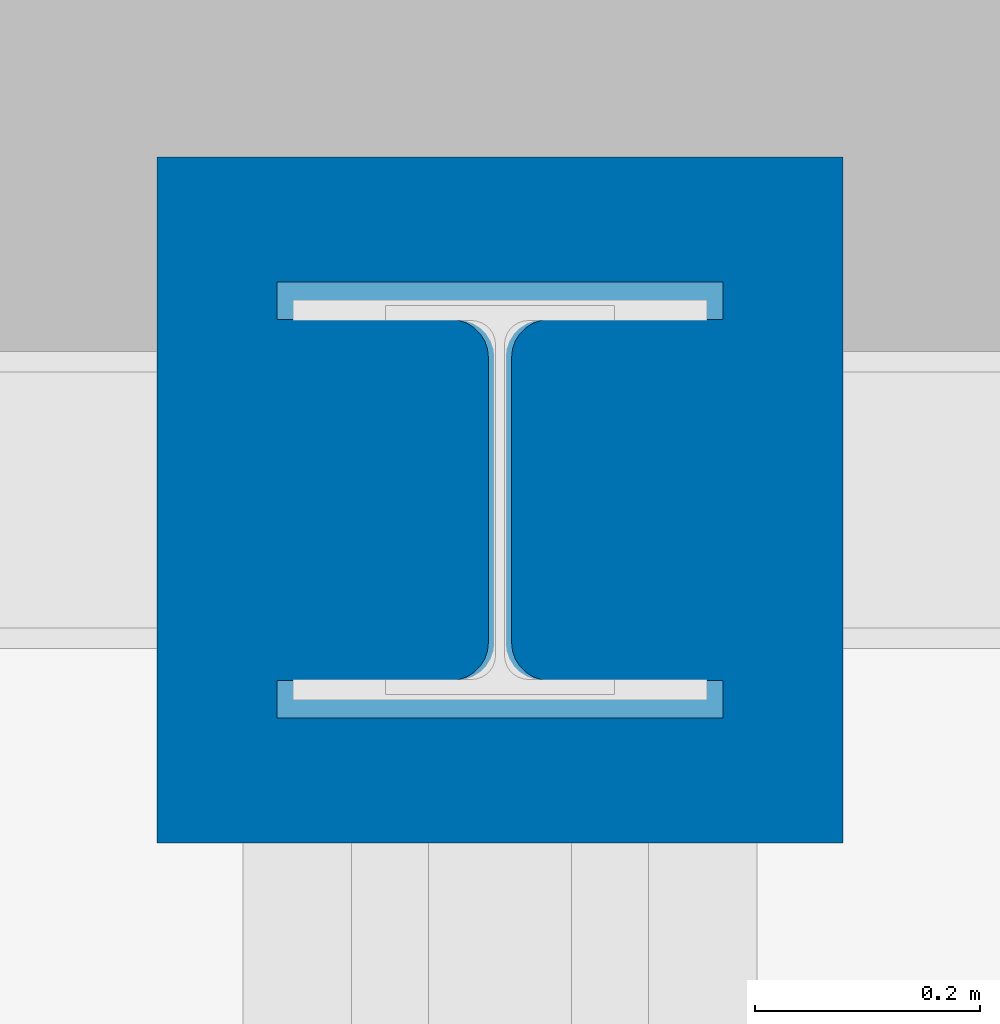
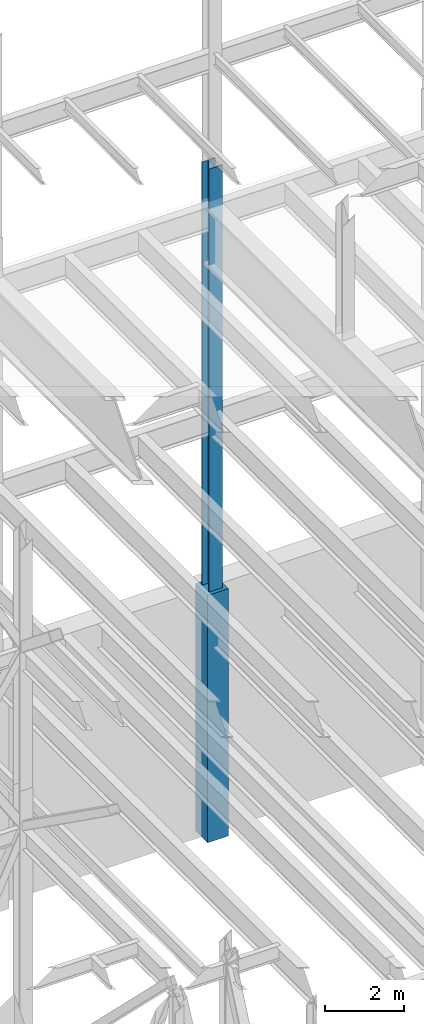
# One storey, part 59 of 150: 2 columns.
"""IFC2X3 building model written with IfcOpenShell, lengths in millimetres."""

from ifc_helpers import new_model, si_unit, frame, origin_with_axes, origin_2d_with_axis, place, context, subcontext, project, spatial, rectangle, i_section, extrude, material, type_object, element, save


model = new_model("IFC2X3")

# Units and contexts
model_context = context("Model", 3, precision=1e-05, world=origin_with_axes())
body_context = subcontext(model_context, "Body", "Model", "MODEL_VIEW")
ifc_project = project(units=[si_unit("LENGTHUNIT", "METRE", prefix="MILLI"), si_unit("AREAUNIT", "SQUARE_METRE"), si_unit("VOLUMEUNIT", "CUBIC_METRE"), si_unit("MASSUNIT", "GRAM", prefix="KILO"), si_unit("TIMEUNIT", "SECOND"), si_unit("PLANEANGLEUNIT", "RADIAN"), si_unit("SOLIDANGLEUNIT", "STERADIAN"), si_unit("THERMODYNAMICTEMPERATUREUNIT", "DEGREE_CELSIUS"), si_unit("LUMINOUSINTENSITYUNIT", "LUMEN")], contexts=[model_context])

# Site, building, storey
site_placement = place(None, origin_with_axes())
site = spatial("IfcSite", under=ifc_project, at=site_placement, CompositionType="ELEMENT")
building_placement = place(site_placement, origin_with_axes())
building = spatial("IfcBuilding", under=site, at=building_placement, Name="Undefined", CompositionType="ELEMENT")
storey_placement = place(building_placement, origin_with_axes())
storey = spatial("IfcBuildingStorey", under=building, at=storey_placement, Name="Undefined", CompositionType="ELEMENT", Elevation=0.0)

# Columns
ifc_material_1 = material(Name="STEEL/A992")
column_type_1 = type_object("IfcColumnType", Name="W14X176", PredefinedType="NOTDEFINED")
column_1_placement = place(storey_placement, frame((18186.4, 38862.0, 22707.6), z_axis=(0.0, 0.0, 1.0), x_axis=(1.0, 0.0, 0.0)))
element("IfcColumn", 1, at=column_1_placement, inside=storey, type_object=column_type_1, material=ifc_material_1, Name="COLUMN", ObjectType="W14X176", context=body_context, shape_type="SweptSolid", body=[
    extrude(i_section(OverallWidth=396.875, OverallDepth=387.35, WebThickness=20.6375, FlangeThickness=33.274, FilletRadius=33.401, at=origin_2d_with_axis()), frame((0.0, 0.0, 14097.0012877801), z_axis=(0.0, 0.0, -1.0), x_axis=(-1.0, 0.0, 0.0)), (0.0, 0.0, 1.0), 14097.0012877801),
])
ifc_material_2 = material(Name="CONCRETE/5000")
column_type_2 = type_object("IfcColumnType", PredefinedType="NOTDEFINED")
column_2_placement = place(storey_placement, frame((18186.4, 38862.0, 16154.4), z_axis=(0.0, 0.0, 1.0), x_axis=(1.0, 0.0, 0.0)))
element("IfcColumn", 2, at=column_2_placement, inside=storey, type_object=column_type_2, material=ifc_material_2, Name="COLUMN", context=body_context, shape_type="SweptSolid", body=[
    extrude(rectangle(XDim=609.6, YDim=609.6, at=origin_2d_with_axis()), frame((0.0, 0.0, 7620.0), z_axis=(0.0, 0.0, -1.0), x_axis=(0.0, -1.0, 0.0)), (0.0, 0.0, 1.0), 7620.0),
])

save(model, "model.ifc")
